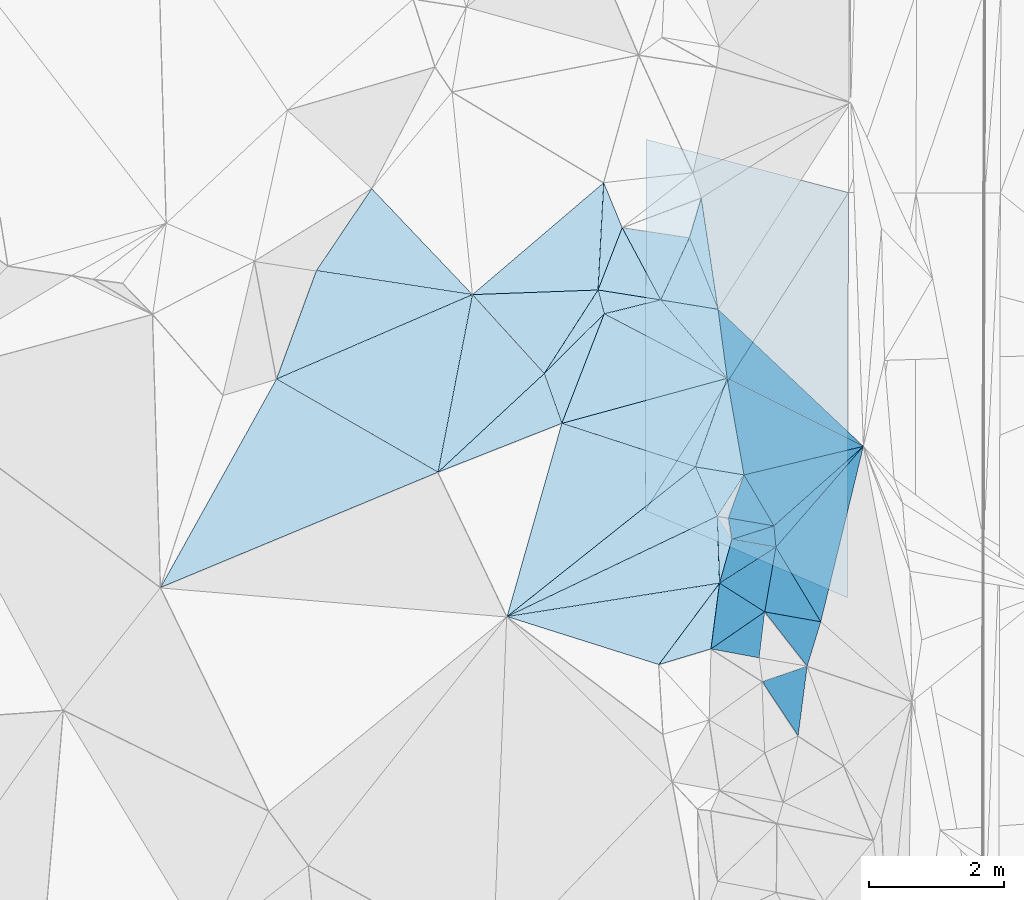
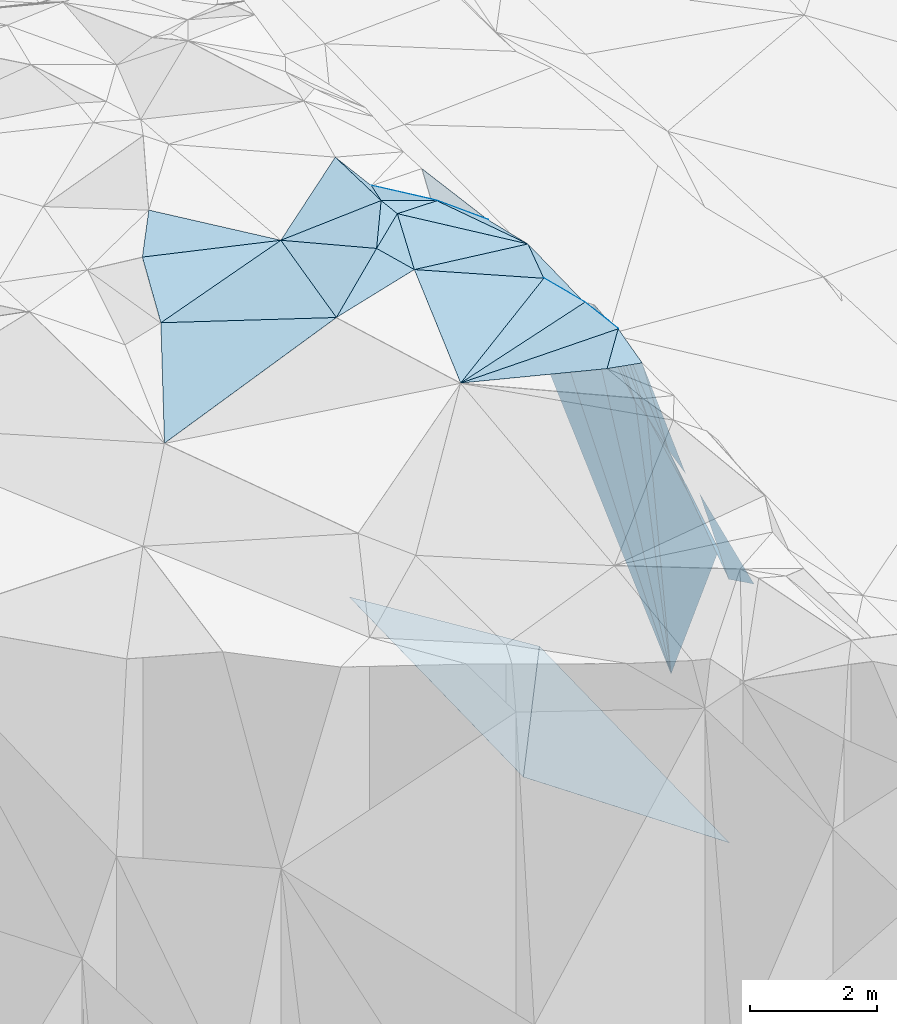
# One storey, part 87 of 275: 45 plates.
"""IFC2X3 building model written with IfcOpenShell, lengths in millimetres."""

import ifcopenshell
import ifcopenshell.guid

model = None  # the IFC model being written
_history = None  # IfcOwnerHistory: only IFC2X3 demands one
_inside = {}  # id of a spatial element -> (the spatial element, [elements in it])
_under = {}  # id of a project, library or spatial element -> (it, [spatial elements below it])
_declared = {}  # id of a project -> (the project, [libraries it declares])
_typed = {}  # id of a type object -> (the type object, [elements of that type])
_made_of = {}  # id of a material, layer set ... -> (it, [elements and type objects made of it])


def new_model(schema):
    """Start an empty IFC model of exactly this schema.

    Asked for "IFC4X3", IfcOpenShell would pick the latest addendum, in which some entities
    have other attributes; the version numbers below select the first issue.
    IFC2X3 requires an IfcOwnerHistory on every rooted entity: one is made here for all.
    """
    global model, _history
    if schema == "IFC4X3":
        model = ifcopenshell.file(schema_version=(4, 3, 0, 0))
    else:
        model = ifcopenshell.file(schema=schema)
    _inside.clear()
    _under.clear()
    _declared.clear()
    _typed.clear()
    _made_of.clear()
    _history = None
    if model.schema == "IFC2X3":
        org = make("IfcOrganization", Name="unknown")
        user = make(
            "IfcPersonAndOrganization",
            ThePerson=make("IfcPerson", FamilyName="unknown"),
            TheOrganization=org,
        )
        app = make(
            "IfcApplication",
            ApplicationDeveloper=org,
            Version="unknown",
            ApplicationFullName="unknown",
            ApplicationIdentifier="unknown",
        )
        _history = make(
            "IfcOwnerHistory",
            OwningUser=user,
            OwningApplication=app,
            ChangeAction="ADDED",
            CreationDate=0,
        )
    return model


def make(cls, **values):
    """One entity of the class cls with the attributes given. An attribute that is None is left unset."""
    return model.create_entity(
        cls, **{name: value for name, value in values.items() if value is not None}
    )


def rooted(cls, **values):
    """An entity with a GlobalId (a new one), such as an element, a storey or a relation."""
    return make(cls, GlobalId=ifcopenshell.guid.new(), OwnerHistory=_history, **values)


def si_unit(unit_type, name, prefix=None):
    """IfcSIUnit, for example si_unit("LENGTHUNIT", "METRE", prefix="MILLI")."""
    return make("IfcSIUnit", UnitType=unit_type, Prefix=prefix, Name=name)


def assignment(units):
    """IfcUnitAssignment: the units of a project."""
    return None if units is None else make("IfcUnitAssignment", Units=units)


def point(xyz):
    """IfcCartesianPoint."""
    return None if xyz is None else make("IfcCartesianPoint", Coordinates=xyz)


def direction(xyz):
    """IfcDirection."""
    return None if xyz is None else make("IfcDirection", DirectionRatios=xyz)


def frame(location, z_axis=None, x_axis=None):
    """IfcAxis2Placement3D, a coordinate frame: its origin and axes. An axis left out is left unset."""
    return make(
        "IfcAxis2Placement3D",
        Location=point(location),
        Axis=direction(z_axis),
        RefDirection=direction(x_axis),
    )


def origin_with_axes():
    """The frame at (0, 0, 0) with the z axis (0, 0, 1) and the x axis (1, 0, 0) written out."""
    return frame((0.0, 0.0, 0.0), z_axis=(0.0, 0.0, 1.0), x_axis=(1.0, 0.0, 0.0))


def place(relative_to, where):
    """IfcLocalPlacement: puts the frame where relative to a parent placement (None: the world)."""
    return make(
        "IfcLocalPlacement", PlacementRelTo=relative_to, RelativePlacement=where
    )


def context(
    kind, dimensions, precision=None, world=None, true_north=None, identifier=None
):
    """IfcGeometricRepresentationContext, for example the 3D "Model" context."""
    return make(
        "IfcGeometricRepresentationContext",
        ContextIdentifier=identifier,
        ContextType=kind,
        CoordinateSpaceDimension=dimensions,
        Precision=precision,
        WorldCoordinateSystem=world,
        TrueNorth=true_north,
    )


def subcontext(parent, identifier, kind, view, scale=None):
    """IfcGeometricRepresentationSubContext, for example "Body" below "Model"."""
    return make(
        "IfcGeometricRepresentationSubContext",
        ContextIdentifier=identifier,
        ContextType=kind,
        ParentContext=parent,
        TargetScale=scale,
        TargetView=view,
    )


def project(units=None, contexts=None):
    """IfcProject with its units and contexts."""
    return rooted(
        "IfcProject",
        Name="project",
        RepresentationContexts=contexts,
        UnitsInContext=assignment(units),
    )


def spatial(cls, under=None, at=None, **own):
    """A site, building, storey or space (cls), placed at a placement, below another one or the project."""
    s = rooted(cls, ObjectPlacement=at, **own)
    if under is not None:
        _under.setdefault(under.id(), (under, []))[1].append(s)
    return s


def polyline(points):
    """IfcPolyline through the points."""
    return make("IfcPolyline", Points=[point(p) for p in points])


def outline(outer, holes=None, kind="AREA"):
    """IfcArbitraryClosedProfileDef: a profile drawn as a closed curve; with holes, ...WithVoids."""
    if holes is None:
        return make("IfcArbitraryClosedProfileDef", ProfileType=kind, OuterCurve=outer)
    return make(
        "IfcArbitraryProfileDefWithVoids",
        ProfileType=kind,
        OuterCurve=outer,
        InnerCurves=holes,
    )


def extrude(swept, where, along, depth):
    """IfcExtrudedAreaSolid: the profile swept, set in the frame where, extruded along a direction by depth."""
    return make(
        "IfcExtrudedAreaSolid",
        SweptArea=swept,
        Position=where,
        ExtrudedDirection=direction(along),
        Depth=depth,
    )


def shape(context_of_items, identifier, shape_type, items):
    """IfcShapeRepresentation: the items that make up one representation, for example the "Body"."""
    return make(
        "IfcShapeRepresentation",
        ContextOfItems=context_of_items,
        RepresentationIdentifier=identifier,
        RepresentationType=shape_type,
        Items=items,
    )


def material(Name=None, Category=None):
    """IfcMaterial."""
    return make("IfcMaterial", Name=Name, Category=Category)


def made_of(thing, what):
    """Note that an element or type object is made of a material, layer set ...; save() writes the relation."""
    if what is not None:
        _made_of.setdefault(what.id(), (what, []))[1].append(thing)
    return thing


def type_object(cls, material=None, **own):
    """A type object (cls), such as IfcWallType, which elements share."""
    return made_of(rooted(cls, **own), material)


def element(
    cls,
    number,
    at=None,
    inside=None,
    cuts=None,
    type_object=None,
    material=None,
    context=None,
    identifier="Body",
    shape_type=None,
    held_by="IfcProductDefinitionShape",
    body=None,
    shapes=None,
    **own,
):
    """One element of the class cls, such as IfcWall. Its Tag is "e" and its number.

    at: its placement. inside: the storey or other place that contains it. cuts: it is an
    opening in that element (IfcRelVoidsElement). A single representation is given by context,
    identifier, shape_type and body (its items); several are given by shapes. held_by: the class
    of the entity that holds the representations. save() writes the other relations.
    """
    e = rooted(cls, Tag="e%d" % number, ObjectPlacement=at, **own)
    if body is not None:
        shapes = [shape(context, identifier, shape_type, body)]
    if shapes is not None:
        e.Representation = make(held_by, Representations=shapes)
    if inside is not None:
        _inside.setdefault(inside.id(), (inside, []))[1].append(e)
    if cuts is not None:
        rooted(
            "IfcRelVoidsElement", RelatingBuildingElement=cuts, RelatedOpeningElement=e
        )
    if type_object is not None:
        _typed.setdefault(type_object.id(), (type_object, []))[1].append(e)
    return made_of(e, material)


def aggregate(whole, parts):
    """IfcRelAggregates: a whole, such as a stair, and the parts it consists of."""
    return rooted("IfcRelAggregates", RelatingObject=whole, RelatedObjects=parts)


def save(model, path):
    """Write the relations noted so far, then the file.

    IfcRelAggregates (storeys below a building ...), IfcRelContainedInSpatialStructure (elements
    in a storey), IfcRelDefinesByType, IfcRelAssociatesMaterial and IfcRelDeclares: one each for
    every whole, place, type object, material and project.
    """
    for whole, parts in _under.values():
        aggregate(whole, parts)
    for where, things in _inside.values():
        rooted(
            "IfcRelContainedInSpatialStructure",
            RelatedElements=things,
            RelatingStructure=where,
        )
    for kind, things in _typed.values():
        rooted("IfcRelDefinesByType", RelatedObjects=things, RelatingType=kind)
    for what, things in _made_of.values():
        rooted("IfcRelAssociatesMaterial", RelatedObjects=things, RelatingMaterial=what)
    for by, libraries in _declared.values():
        rooted("IfcRelDeclares", RelatingContext=by, RelatedDefinitions=libraries)
    model.write(path)


model = new_model("IFC2X3")

# Units and contexts
model_context = context("Model", 3, precision=1e-05, world=origin_with_axes())
body_context = subcontext(model_context, "Body", "Model", "MODEL_VIEW")
ifc_project = project(units=[si_unit("LENGTHUNIT", "METRE", prefix="MILLI"), si_unit("AREAUNIT", "SQUARE_METRE"), si_unit("VOLUMEUNIT", "CUBIC_METRE"), si_unit("MASSUNIT", "GRAM", prefix="KILO"), si_unit("TIMEUNIT", "SECOND"), si_unit("PLANEANGLEUNIT", "RADIAN"), si_unit("SOLIDANGLEUNIT", "STERADIAN"), si_unit("THERMODYNAMICTEMPERATUREUNIT", "DEGREE_CELSIUS"), si_unit("LUMINOUSINTENSITYUNIT", "LUMEN")], contexts=[model_context])

# Site, building, storey
site_placement = place(None, origin_with_axes())
site = spatial("IfcSite", under=ifc_project, at=site_placement, CompositionType="ELEMENT")
building_placement = place(site_placement, origin_with_axes())
building = spatial("IfcBuilding", under=site, at=building_placement, Name="Undefined", CompositionType="ELEMENT")
storey_placement = place(building_placement, origin_with_axes())
storey = spatial("IfcBuildingStorey", under=building, at=storey_placement, Name="Undefined", CompositionType="ELEMENT", Elevation=0.0)

# Plates
ifc_material = material()
plate_type_1 = type_object("IfcPlateType", PredefinedType="NOTDEFINED")
plate_1_placement = place(storey_placement, frame((-107344.660110587, 97239.4910074522, 53279.5045122892), z_axis=(-0.102362017447469, 0.0870254570659908, -0.990933190082227), x_axis=(0.344971449762898, 0.937451020984177, 0.0466934910261504)))
element("IfcPlate", 1, at=plate_1_placement, inside=storey, type_object=plate_type_1, material=ifc_material, Name="00", context=body_context, shape_type="SweptSolid", body=[
    extrude(outline(polyline([(0.0, 0.0), (1713.30090332031, 1.26019585877657e-08), (2164.41845703125, 2310.38818359375), (0.0, 0.0)])), frame((-8.85201319254618e-08, 2.18876761149539e-07, -0.5000001331573), z_axis=(0.0, 0.0, 1.0), x_axis=(1.0, 0.0, 0.0)), (0.0, 0.0, 1.0), 1.0),
])
plate_type_2 = type_object("IfcPlateType", PredefinedType="NOTDEFINED")
plate_2_placement = place(storey_placement, frame((-100815.213242628, 95206.0457130545, 52619.6742989896), z_axis=(-0.754729440093031, -0.0781614138086887, -0.651363389858753), x_axis=(0.475300213105094, -0.749509331662473, -0.460787878717664)))
element("IfcPlate", 2, at=plate_2_placement, inside=storey, type_object=plate_type_2, material=ifc_material, Name="00", context=body_context, shape_type="SweptSolid", body=[
    extrude(outline(polyline([(0.0, 0.0), (455.741149902344, 1.45519152283669e-10), (721.901000976563, 684.513671875), (0.0, 0.0)])), frame((-8.85201319254618e-08, 2.18876761149539e-07, -0.5000001331573), z_axis=(0.0, 0.0, 1.0), x_axis=(1.0, 0.0, 0.0)), (0.0, 0.0, 1.0), 1.0),
])
plate_type_3 = type_object("IfcPlateType", PredefinedType="NOTDEFINED")
plate_3_placement = place(storey_placement, frame((-103378.480245373, 97319.9386348923, 53269.5037275257), z_axis=(0.0415528566033892, -0.11493666031321, -0.992503362323848), x_axis=(-0.668500257960516, 0.735060009693145, -0.113111393133656)))
element("IfcPlate", 3, at=plate_3_placement, inside=storey, type_object=plate_type_3, material=ifc_material, Name="00", context=body_context, shape_type="SweptSolid", body=[
    extrude(outline(polyline([(0.0, 0.0), (1591.35168457031, 2.66118149738759e-09), (389.480224609375, 1424.57189941406), (0.0, 0.0)])), frame((-8.85201319254618e-08, 2.18876761149539e-07, -0.5000001331573), z_axis=(0.0, 0.0, 1.0), x_axis=(1.0, 0.0, 0.0)), (0.0, 0.0, 1.0), 1.0),
])
plate_type_4 = type_object("IfcPlateType", PredefinedType="NOTDEFINED")
plate_4_placement = place(storey_placement, frame((-98871.7360586173, 100000.516631824, 42424.2168338371), z_axis=(-0.446934287543487, 0.0205258010018678, -0.894331277609828), x_axis=(-0.522683826086693, -0.817325183294183, 0.242448268091374)))
element("IfcPlate", 4, at=plate_4_placement, inside=storey, type_object=plate_type_4, material=ifc_material, Name="00_PR", context=body_context, shape_type="SweptSolid", body=[
    extrude(outline(polyline([(0.0, 0.0), (5761.72412109375, -1.54250301420689e-09), (1288.73974609375, 3201.32958984375), (0.0, 0.0)])), frame((-8.85201319254618e-08, 2.18876761149539e-07, -0.5000001331573), z_axis=(0.0, 0.0, 1.0), x_axis=(1.0, 0.0, 0.0)), (0.0, 0.0, 1.0), 1.0),
])
plate_type_5 = type_object("IfcPlateType", PredefinedType="NOTDEFINED")
plate_5_placement = place(storey_placement, frame((-101883.29606058, 95291.3145619174, 43821.1368655032), z_axis=(-0.447056042507758, 0.0206223752256499, -0.894268199421938), x_axis=(0.522683826084668, 0.817325183294846, -0.242448268093504)))
element("IfcPlate", 5, at=plate_5_placement, inside=storey, type_object=plate_type_5, material=ifc_material, Name="00_PR", context=body_context, shape_type="SweptSolid", body=[
    extrude(outline(polyline([(0.0, 0.0), (5761.72412109375, -1.54250301420689e-09), (880.428405761719, 3495.33618164063), (0.0, 0.0)])), frame((-8.85201319254618e-08, 2.18876761149539e-07, -0.5000001331573), z_axis=(0.0, 0.0, 1.0), x_axis=(1.0, 0.0, 0.0)), (0.0, 0.0, 1.0), 1.0),
])
plate_type_6 = type_object("IfcPlateType", PredefinedType="NOTDEFINED")
plate_6_placement = place(storey_placement, frame((-101652.583225246, 98411.0017933798, 52919.6181627559), z_axis=(-0.571172440477387, -0.301041298099992, -0.763633537815998), x_axis=(0.347639344976047, 0.75404379107532, -0.557283452980065)))
element("IfcPlate", 6, at=plate_6_placement, inside=storey, type_object=plate_type_6, material=ifc_material, Name="00", context=body_context, shape_type="SweptSolid", body=[
    extrude(outline(polyline([(0.0, 0.0), (1220.20495605469, -1.57160684466362e-09), (513.602233886719, 901.06201171875), (0.0, 0.0)])), frame((-8.85201319254618e-08, 2.18876761149539e-07, -0.5000001331573), z_axis=(0.0, 0.0, 1.0), x_axis=(1.0, 0.0, 0.0)), (0.0, 0.0, 1.0), 1.0),
])
plate_type_7 = type_object("IfcPlateType", PredefinedType="NOTDEFINED")
plate_7_placement = place(storey_placement, frame((-100781.715139646, 94215.1018659896, 52699.8435163676), z_axis=(-0.941438421919234, 0.125572215780303, -0.312930210044103), x_axis=(0.249200434863564, 0.884299250915346, -0.394859440933566)))
element("IfcPlate", 7, at=plate_7_placement, inside=storey, type_object=plate_type_7, material=ifc_material, Name="00", context=body_context, shape_type="SweptSolid", body=[
    extrude(outline(polyline([(0.0, 0.0), (734.438537597656, 9.45874489843845e-10), (1588.15185546875, 1936.66552734375), (0.0, 0.0)])), frame((-8.85201319254618e-08, 2.18876761149539e-07, -0.5000001331573), z_axis=(0.0, 0.0, 1.0), x_axis=(1.0, 0.0, 0.0)), (0.0, 0.0, 1.0), 1.0),
])
plate_type_8 = type_object("IfcPlateType", PredefinedType="NOTDEFINED")
plate_8_placement = place(storey_placement, frame((-100804.221469901, 98272.3390613483, 52339.8925138729), z_axis=(-0.964955034889042, -0.15055260443843, -0.214931835564427), x_axis=(0.245796147254959, -0.231705745016407, -0.941220857036759)))
element("IfcPlate", 8, at=plate_8_placement, inside=storey, type_object=plate_type_8, material=ifc_material, Name="00", context=body_context, shape_type="SweptSolid", body=[
    extrude(outline(polyline([(0.0, 0.0), (8763.0869140625, 2.7488567866385e-08), (166.634201049805, 1023.97900390625), (0.0, 0.0)])), frame((-8.85201319254618e-08, 2.18876761149539e-07, -0.5000001331573), z_axis=(0.0, 0.0, 1.0), x_axis=(1.0, 0.0, 0.0)), (0.0, 0.0, 1.0), 1.0),
])
plate_type_9 = type_object("IfcPlateType", PredefinedType="NOTDEFINED")
plate_9_placement = place(storey_placement, frame((-100669.018904396, 97249.7342922777, 52449.6394057601), z_axis=(-0.687983318729033, 0.081374169104235, -0.721149913508406), x_axis=(0.165916843196939, -0.949739777549847, -0.265454244801491)))
element("IfcPlate", 9, at=plate_9_placement, inside=storey, type_object=plate_type_9, material=ifc_material, Name="00", context=body_context, shape_type="SweptSolid", body=[
    extrude(outline(polyline([(0.0, 0.0), (1506.85107421875, 4.13274392485619e-09), (1088.4287109375, 920.338439941406), (0.0, 0.0)])), frame((-8.85201319254618e-08, 2.18876761149539e-07, -0.5000001331573), z_axis=(0.0, 0.0, 1.0), x_axis=(1.0, 0.0, 0.0)), (0.0, 0.0, 1.0), 1.0),
])
plate_type_10 = type_object("IfcPlateType", PredefinedType="NOTDEFINED")
plate_10_placement = place(storey_placement, frame((-100419.147354293, 95818.521492825, 52049.8893431669), z_axis=(-0.968814101984016, -0.111519062820364, -0.221275245846824), x_axis=(0.216686648109872, 0.0518643959820866, -0.974862544649409)))
element("IfcPlate", 10, at=plate_10_placement, inside=storey, type_object=plate_type_10, material=ifc_material, Name="00", context=body_context, shape_type="SweptSolid", body=[
    extrude(outline(polyline([(0.0, 0.0), (8163.2021484375, 1.34168658405542e-08), (1577.65783691406, 843.502014160156), (0.0, 0.0)])), frame((-8.85201319254618e-08, 2.18876761149539e-07, -0.5000001331573), z_axis=(0.0, 0.0, 1.0), x_axis=(1.0, 0.0, 0.0)), (0.0, 0.0, 1.0), 1.0),
])
plate_type_11 = type_object("IfcPlateType", PredefinedType="NOTDEFINED")
plate_11_placement = place(storey_placement, frame((-100112.386916383, 93789.4709752747, 50389.8170202238), z_axis=(-0.872840817326139, 0.322876915783165, -0.36592267607213), x_axis=(0.365398242166179, -0.064617253957624, -0.928605801787197)))
element("IfcPlate", 11, at=plate_11_placement, inside=storey, type_object=plate_type_11, material=ifc_material, Name="00", context=body_context, shape_type="SweptSolid", body=[
    extrude(outline(polyline([(0.0, 0.0), (2272.2236328125, -2.17551132664084e-09), (2334.01318359375, 692.157531738281), (0.0, 0.0)])), frame((-8.85201319254618e-08, 2.18876761149539e-07, -0.5000001331573), z_axis=(0.0, 0.0, 1.0), x_axis=(1.0, 0.0, 0.0)), (0.0, 0.0, 1.0), 1.0),
])
plate_type_12 = type_object("IfcPlateType", PredefinedType="NOTDEFINED")
plate_12_placement = place(storey_placement, frame((-100193.973477224, 93108.2299145058, 50379.8495838133), z_axis=(-0.946395220256824, 0.117723884982398, -0.300794238607869), x_axis=(-0.296236861181378, 0.0548833859624551, 0.953536331779079)))
element("IfcPlate", 12, at=plate_12_placement, inside=storey, type_object=plate_type_12, material=ifc_material, Name="00", context=body_context, shape_type="SweptSolid", body=[
    extrude(outline(polyline([(0.0, 0.0), (2412.07373046875, -5.84986992180347e-09), (22.760498046875, 685.698181152344), (0.0, 0.0)])), frame((-8.85201319254618e-08, 2.18876761149539e-07, -0.5000001331573), z_axis=(0.0, 0.0, 1.0), x_axis=(1.0, 0.0, 0.0)), (0.0, 0.0, 1.0), 1.0),
])
plate_13_placement = place(storey_placement, frame((-101652.585016621, 98411.0712264474, 52919.5989324793), z_axis=(-0.57475614055303, -0.162174528284192, -0.802094010245923), x_axis=(0.818156298329736, -0.133767240893072, -0.559219631957999)))
element("IfcPlate", 13, at=plate_13_placement, inside=storey, type_object=plate_type_12, material=ifc_material, Name="00", context=body_context, shape_type="SweptSolid", body=[
    extrude(outline(polyline([(0.0, 0.0), (1037.15954589844, 3.02679836750031e-09), (1222.95544433594, 1020.67620849609), (0.0, 0.0)])), frame((-8.85201319254618e-08, 2.18876761149539e-07, -0.5000001331573), z_axis=(0.0, 0.0, 1.0), x_axis=(1.0, 0.0, 0.0)), (0.0, 0.0, 1.0), 1.0),
])
plate_type_13 = type_object("IfcPlateType", PredefinedType="NOTDEFINED")
plate_14_placement = place(storey_placement, frame((-99975.8941214344, 95063.3567860404, 50489.8403549941), z_axis=(-0.941631828942803, 0.106803743463661, -0.31925297039179), x_axis=(-0.315045255326662, 0.0546446800053478, 0.947502214268268)))
element("IfcPlate", 14, at=plate_14_placement, inside=storey, type_object=plate_type_13, material=ifc_material, Name="00", context=body_context, shape_type="SweptSolid", body=[
    extrude(outline(polyline([(0.0, 0.0), (2142.47509765625, 4.78758011013269e-09), (1659.01574707031, 669.452697753906), (0.0, 0.0)])), frame((-8.85201319254618e-08, 2.18876761149539e-07, -0.5000001331573), z_axis=(0.0, 0.0, 1.0), x_axis=(1.0, 0.0, 0.0)), (0.0, 0.0, 1.0), 1.0),
])
plate_type_14 = type_object("IfcPlateType", PredefinedType="NOTDEFINED")
plate_15_placement = place(storey_placement, frame((-99946.0696637616, 94748.4703674761, 50399.8956807153), z_axis=(-0.977443110590562, -0.033019411700747, -0.208601735395424), x_axis=(-0.0907654072870501, 0.957512935214232, 0.273734578994766)))
element("IfcPlate", 15, at=plate_15_placement, inside=storey, type_object=plate_type_14, material=ifc_material, Name="00", context=body_context, shape_type="SweptSolid", body=[
    extrude(outline(polyline([(0.0, 0.0), (328.78564453125, -2.5029294192791e-09), (-414.3125, 6597.6279296875), (0.0, 0.0)])), frame((-8.85201319254618e-08, 2.18876761149539e-07, -0.5000001331573), z_axis=(0.0, 0.0, 1.0), x_axis=(1.0, 0.0, 0.0)), (0.0, 0.0, 1.0), 1.0),
])
plate_type_15 = type_object("IfcPlateType", PredefinedType="NOTDEFINED")
plate_16_placement = place(storey_placement, frame((-101652.438653701, 98411.0085882198, 52919.542314576), z_axis=(-0.282033278242463, -0.287451493909444, -0.915329923368092), x_axis=(-0.957021666869353, 0.151492729793631, 0.247304431748158)))
element("IfcPlate", 16, at=plate_16_placement, inside=storey, type_object=plate_type_15, material=ifc_material, Name="00", context=body_context, shape_type="SweptSolid", body=[
    extrude(outline(polyline([(0.0, 0.0), (970.463806152344, -8.58562998473644e-10), (669.576721191406, 1024.43493652344), (0.0, 0.0)])), frame((-8.85201319254618e-08, 2.18876761149539e-07, -0.5000001331573), z_axis=(0.0, 0.0, 1.0), x_axis=(1.0, 0.0, 0.0)), (0.0, 0.0, 1.0), 1.0),
])
plate_type_16 = type_object("IfcPlateType", PredefinedType="NOTDEFINED")
plate_17_placement = place(storey_placement, frame((-102490.479406872, 98204.7175444551, 53089.5177065496), z_axis=(-0.228286030459364, 0.132427229372002, -0.964545756933263), x_axis=(-0.244033509207427, 0.951297067808466, 0.188365429850922)))
element("IfcPlate", 17, at=plate_17_placement, inside=storey, type_object=plate_type_16, material=ifc_material, Name="00", context=body_context, shape_type="SweptSolid", body=[
    extrude(outline(polyline([(0.0, 0.0), (371.618072509766, -3.34694050252438e-10), (-40.0949287414551, 878.801696777344), (0.0, 0.0)])), frame((-8.85201319254618e-08, 2.18876761149539e-07, -0.5000001331573), z_axis=(0.0, 0.0, 1.0), x_axis=(1.0, 0.0, 0.0)), (0.0, 0.0, 1.0), 1.0),
])
plate_type_17 = type_object("IfcPlateType", PredefinedType="NOTDEFINED")
plate_18_placement = place(storey_placement, frame((-100668.794257987, 97249.7854669593, 52449.5232018861), z_axis=(-0.23869593819257, 0.183721524600985, -0.953556841771196), x_axis=(-0.845689402985507, 0.443323216734611, 0.29710933876621)))
element("IfcPlate", 18, at=plate_18_placement, inside=storey, type_object=plate_type_17, material=ifc_material, Name="00", context=body_context, shape_type="SweptSolid", body=[
    extrude(outline(polyline([(0.0, 0.0), (2154.08911132813, 2.17551132664084e-09), (1486.38232421875, 572.771850585938), (0.0, 0.0)])), frame((-8.85201319254618e-08, 2.18876761149539e-07, -0.5000001331573), z_axis=(0.0, 0.0, 1.0), x_axis=(1.0, 0.0, 0.0)), (0.0, 0.0, 1.0), 1.0),
])
plate_type_18 = type_object("IfcPlateType", PredefinedType="NOTDEFINED")
plate_19_placement = place(storey_placement, frame((-101680.208855018, 93008.4579098496, 52979.50861603), z_axis=(-0.0866350012075543, -0.163519365232123, -0.982728748821286), x_axis=(-0.952951068923403, 0.30122391275125, 0.0338882667684678)))
element("IfcPlate", 19, at=plate_19_placement, inside=storey, type_object=plate_type_18, material=ifc_material, Name="00", context=body_context, shape_type="SweptSolid", body=[
    extrude(outline(polyline([(0.0, 0.0), (2360.69897460938, 1.97906047105789e-09), (-502.690093994141, 1445.47668457031), (0.0, 0.0)])), frame((-8.85201319254618e-08, 2.18876761149539e-07, -0.5000001331573), z_axis=(0.0, 0.0, 1.0), x_axis=(1.0, 0.0, 0.0)), (0.0, 0.0, 1.0), 1.0),
])
plate_type_19 = type_object("IfcPlateType", PredefinedType="NOTDEFINED")
plate_20_placement = place(storey_placement, frame((-100781.433956859, 94215.0732117764, 52699.5385587893), z_axis=(-0.379075628872105, 0.06826585103134, -0.9228442128432), x_axis=(-0.129006544744459, -0.991434957826339, -0.0203478699863755)))
element("IfcPlate", 20, at=plate_20_placement, inside=storey, type_object=plate_type_19, material=ifc_material, Name="00", context=body_context, shape_type="SweptSolid", body=[
    extrude(outline(polyline([(0.0, 0.0), (982.903869628906, 6.81029632687569e-09), (1306.43493652344, 797.074401855469), (0.0, 0.0)])), frame((-8.85201319254618e-08, 2.18876761149539e-07, -0.5000001331573), z_axis=(0.0, 0.0, 1.0), x_axis=(1.0, 0.0, 0.0)), (0.0, 0.0, 1.0), 1.0),
])
plate_type_20 = type_object("IfcPlateType", PredefinedType="NOTDEFINED")
plate_21_placement = place(storey_placement, frame((-100814.88599314, 95206.0430804497, 52619.5042503508), z_axis=(-0.100234591356631, -0.0834308647266623, -0.991459690308452), x_axis=(0.0337658032048205, -0.996189371820995, 0.0804152100340744)))
element("IfcPlate", 21, at=plate_21_placement, inside=storey, type_object=plate_type_20, material=ifc_material, Name="00", context=body_context, shape_type="SweptSolid", body=[
    extrude(outline(polyline([(0.0, 0.0), (994.836669921875, 8.29459168016911e-10), (1410.9853515625, 3180.443359375), (0.0, 0.0)])), frame((-8.85201319254618e-08, 2.18876761149539e-07, -0.5000001331573), z_axis=(0.0, 0.0, 1.0), x_axis=(1.0, 0.0, 0.0)), (0.0, 0.0, 1.0), 1.0),
])
plate_type_21 = type_object("IfcPlateType", PredefinedType="NOTDEFINED")
plate_22_placement = place(storey_placement, frame((-103378.55080737, 97320.0122386982, 53269.5027170647), z_axis=(-0.0994864296260352, 0.0322758273111082, -0.994515319787306), x_axis=(0.332327347639212, -0.941004880829664, -0.06378360499248)))
element("IfcPlate", 22, at=plate_22_placement, inside=storey, type_object=plate_type_21, material=ifc_material, Name="00", context=body_context, shape_type="SweptSolid", body=[
    extrude(outline(polyline([(0.0, 0.0), (783.900512695313, -5.70435076951981e-09), (844.877624511719, 1977.1650390625), (0.0, 0.0)])), frame((-8.85201319254618e-08, 2.18876761149539e-07, -0.5000001331573), z_axis=(0.0, 0.0, 1.0), x_axis=(1.0, 0.0, 0.0)), (0.0, 0.0, 1.0), 1.0),
])
plate_type_22 = type_object("IfcPlateType", PredefinedType="NOTDEFINED")
plate_23_placement = place(storey_placement, frame((-100112.41978631, 93789.3925115726, 50389.8487177517), z_axis=(-0.938582630391391, 0.165951424860966, -0.302527305402658), x_axis=(-0.274031657311512, 0.174308130014904, 0.945792433148951)))
element("IfcPlate", 23, at=plate_23_placement, inside=storey, type_object=plate_type_22, material=ifc_material, Name="00", context=body_context, shape_type="SweptSolid", body=[
    extrude(outline(polyline([(0.0, 0.0), (2442.396484375, 4.14729584008455e-09), (131.059814453125, 964.688171386719), (0.0, 0.0)])), frame((-8.85201319254618e-08, 2.18876761149539e-07, -0.5000001331573), z_axis=(0.0, 0.0, 1.0), x_axis=(1.0, 0.0, 0.0)), (0.0, 0.0, 1.0), 1.0),
])
plate_type_23 = type_object("IfcPlateType", PredefinedType="NOTDEFINED")
plate_24_placement = place(storey_placement, frame((-105934.903532407, 100060.353808086, 53239.5035985636), z_axis=(-0.118750753045522, -0.0180337586479, -0.992760314577568), x_axis=(0.687208357335265, -0.723169892053667, -0.0690650478581938)))
element("IfcPlate", 24, at=plate_24_placement, inside=storey, type_object=plate_type_23, material=ifc_material, Name="00", context=body_context, shape_type="SweptSolid", body=[
    extrude(outline(polyline([(0.0, 0.0), (2171.86547851563, 1.43554643727839e-08), (307.569671630859, 1437.28942871094), (0.0, 0.0)])), frame((-8.85201319254618e-08, 2.18876761149539e-07, -0.5000001331573), z_axis=(0.0, 0.0, 1.0), x_axis=(1.0, 0.0, 0.0)), (0.0, 0.0, 1.0), 1.0),
])
plate_type_24 = type_object("IfcPlateType", PredefinedType="NOTDEFINED")
plate_25_placement = place(storey_placement, frame((-102224.104605899, 99481.2500253093, 52759.6006950824), z_axis=(-0.473142042835989, -0.372055464178987, -0.798568305704369), x_axis=(0.878594200230698, -0.13252284886064, -0.458813606871942)))
element("IfcPlate", 25, at=plate_25_placement, inside=storey, type_object=plate_type_24, material=ifc_material, Name="00", context=body_context, shape_type="SweptSolid", body=[
    extrude(outline(polyline([(0.0, 0.0), (1133.35778808594, 1.76078174263239e-09), (570.605285644531, 1082.68627929688), (0.0, 0.0)])), frame((-8.85201319254618e-08, 2.18876761149539e-07, -0.5000001331573), z_axis=(0.0, 0.0, 1.0), x_axis=(1.0, 0.0, 0.0)), (0.0, 0.0, 1.0), 1.0),
])
plate_type_25 = type_object("IfcPlateType", PredefinedType="NOTDEFINED")
plate_26_placement = place(storey_placement, frame((-102581.203351381, 98558.2255956234, 53159.5264615429), z_axis=(-0.301647010332855, 0.110141143374922, -0.947036435251208), x_axis=(0.24403350922126, -0.95129706780404, -0.188365429855355)))
element("IfcPlate", 26, at=plate_26_placement, inside=storey, type_object=plate_type_25, material=ifc_material, Name="00", context=body_context, shape_type="SweptSolid", body=[
    extrude(outline(polyline([(0.0, 0.0), (371.618072509766, -3.34694050252438e-10), (962.54736328125, 1120.09045410156), (0.0, 0.0)])), frame((-8.85201319254618e-08, 2.18876761149539e-07, -0.5000001331573), z_axis=(0.0, 0.0, 1.0), x_axis=(1.0, 0.0, 0.0)), (0.0, 0.0, 1.0), 1.0),
])
plate_type_26 = type_object("IfcPlateType", PredefinedType="NOTDEFINED")
plate_27_placement = place(storey_placement, frame((-102490.520518681, 98204.6733511666, 53089.5252050554), z_axis=(-0.310511981768277, 0.0440381357937831, -0.949548814845317), x_axis=(0.845689402974647, -0.443323216760005, -0.29710933875923)))
element("IfcPlate", 27, at=plate_27_placement, inside=storey, type_object=plate_type_26, material=ifc_material, Name="00", context=body_context, shape_type="SweptSolid", body=[
    extrude(outline(polyline([(0.0, 0.0), (2154.08911132813, 2.17551132664084e-09), (149.80810546875, 1737.88879394531), (0.0, 0.0)])), frame((-8.85201319254618e-08, 2.18876761149539e-07, -0.5000001331573), z_axis=(0.0, 0.0, 1.0), x_axis=(1.0, 0.0, 0.0)), (0.0, 0.0, 1.0), 1.0),
])
plate_type_27 = type_object("IfcPlateType", PredefinedType="NOTDEFINED")
plate_28_placement = place(storey_placement, frame((-101138.444240057, 95937.709022598, 52749.5220693037), z_axis=(-0.266972180134134, -0.123000398713059, -0.955822555159092), x_axis=(-0.927527263258088, 0.301997252844787, 0.220206346836697)))
element("IfcPlate", 28, at=plate_28_placement, inside=storey, type_object=plate_type_27, material=ifc_material, Name="00", context=body_context, shape_type="SweptSolid", body=[
    extrude(outline(polyline([(0.0, 0.0), (2134.36181640625, -1.04118953458965e-08), (-105.464782714844, 1421.47009277344), (0.0, 0.0)])), frame((-8.85201319254618e-08, 2.18876761149539e-07, -0.5000001331573), z_axis=(0.0, 0.0, 1.0), x_axis=(1.0, 0.0, 0.0)), (0.0, 0.0, 1.0), 1.0),
])
plate_type_28 = type_object("IfcPlateType", PredefinedType="NOTDEFINED")
plate_29_placement = place(storey_placement, frame((-99975.8988792316, 95063.3024326882, 50489.8456187418), z_axis=(-0.951149275832967, -0.00190348107853032, -0.308725495938068), x_axis=(0.0907654072841026, -0.957512935215651, -0.273734578990782)))
element("IfcPlate", 29, at=plate_29_placement, inside=storey, type_object=plate_type_28, material=ifc_material, Name="00", context=body_context, shape_type="SweptSolid", body=[
    extrude(outline(polyline([(0.0, 0.0), (328.78564453125, -2.5029294192791e-09), (-391.744598388672, 1990.05932617188), (0.0, 0.0)])), frame((-8.85201319254618e-08, 2.18876761149539e-07, -0.5000001331573), z_axis=(0.0, 0.0, 1.0), x_axis=(1.0, 0.0, 0.0)), (0.0, 0.0, 1.0), 1.0),
])
plate_30_placement = place(storey_placement, frame((-100598.696338798, 94864.4786382776, 52409.8436457132), z_axis=(-0.948656901720369, -0.0478198247746867, -0.312671308528346), x_axis=(-0.154132647215073, 0.93309082360794, 0.324937904777406)))
element("IfcPlate", 30, at=plate_30_placement, inside=storey, type_object=plate_type_28, material=ifc_material, Name="00", context=body_context, shape_type="SweptSolid", body=[
    extrude(outline(polyline([(0.0, 0.0), (338.526214599609, 1.42608769237995e-09), (-534.375183105469, 1956.58972167969), (0.0, 0.0)])), frame((-8.85201319254618e-08, 2.18876761149539e-07, -0.5000001331573), z_axis=(0.0, 0.0, 1.0), x_axis=(1.0, 0.0, 0.0)), (0.0, 0.0, 1.0), 1.0),
])
plate_type_29 = type_object("IfcPlateType", PredefinedType="NOTDEFINED")
plate_31_placement = place(storey_placement, frame((-104442.300364722, 98489.6765438128, 53089.503801441), z_axis=(0.0392605651328663, -0.116998668753193, -0.992355742430822), x_axis=(0.668500257964939, -0.735060009689736, 0.113111393129671)))
element("IfcPlate", 31, at=plate_31_placement, inside=storey, type_object=plate_type_29, material=ifc_material, Name="00", context=body_context, shape_type="SweptSolid", body=[
    extrude(outline(polyline([(0.0, 0.0), (1591.35168457031, 2.66118149738759e-09), (1625.78771972656, 2149.84057617188), (0.0, 0.0)])), frame((-8.85201319254618e-08, 2.18876761149539e-07, -0.5000001331573), z_axis=(0.0, 0.0, 1.0), x_axis=(1.0, 0.0, 0.0)), (0.0, 0.0, 1.0), 1.0),
])
plate_type_30 = type_object("IfcPlateType", PredefinedType="NOTDEFINED")
plate_32_placement = place(storey_placement, frame((-99282.1657163435, 93642.4162570834, 48279.884825964), z_axis=(-0.963444804926493, -0.136860360741239, -0.230311418557419), x_axis=(-0.267526449315443, 0.445678865051812, 0.854283295027358)))
element("IfcPlate", 32, at=plate_32_placement, inside=storey, type_object=plate_type_30, material=ifc_material, Name="00", context=body_context, shape_type="SweptSolid", body=[
    extrude(outline(polyline([(0.0, 0.0), (2481.6123046875, 1.33804860524833e-08), (-2588.25268554688, 4242.265625), (0.0, 0.0)])), frame((-8.85201319254618e-08, 2.18876761149539e-07, -0.5000001331573), z_axis=(0.0, 0.0, 1.0), x_axis=(1.0, 0.0, 0.0)), (0.0, 0.0, 1.0), 1.0),
])
plate_type_31 = type_object("IfcPlateType", PredefinedType="NOTDEFINED")
plate_33_placement = place(storey_placement, frame((-99946.03808306, 94748.5681026502, 50399.8144475976), z_axis=(-0.914285658311525, 0.162451682650694, -0.371067629698173), x_axis=(0.26752644932045, -0.445678865034267, -0.854283295034943)))
element("IfcPlate", 33, at=plate_33_placement, inside=storey, type_object=plate_type_31, material=ifc_material, Name="00", context=body_context, shape_type="SweptSolid", body=[
    extrude(outline(polyline([(0.0, 0.0), (2481.6123046875, 1.33804860524833e-08), (391.519653320313, 891.354248046875), (0.0, 0.0)])), frame((-8.85201319254618e-08, 2.18876761149539e-07, -0.5000001331573), z_axis=(0.0, 0.0, 1.0), x_axis=(1.0, 0.0, 0.0)), (0.0, 0.0, 1.0), 1.0),
])
plate_type_32 = type_object("IfcPlateType", PredefinedType="NOTDEFINED")
plate_34_placement = place(storey_placement, frame((-102496.682711894, 100147.988976521, 52999.5030231561), z_axis=(0.0411377959971389, -0.102207057201151, -0.993912168754754), x_axis=(-0.0527141628238743, -0.99359085108929, 0.0999921880420579)))
element("IfcPlate", 34, at=plate_34_placement, inside=storey, type_object=plate_type_32, material=ifc_material, Name="00", context=body_context, shape_type="SweptSolid", body=[
    extrude(outline(polyline([(0.0, 0.0), (1600.125, -1.07393134385347e-08), (1759.23754882813, 1857.0361328125), (0.0, 0.0)])), frame((-8.85201319254618e-08, 2.18876761149539e-07, -0.5000001331573), z_axis=(0.0, 0.0, 1.0), x_axis=(1.0, 0.0, 0.0)), (0.0, 0.0, 1.0), 1.0),
])
plate_type_33 = type_object("IfcPlateType", PredefinedType="NOTDEFINED")
plate_35_placement = place(storey_placement, frame((-100803.500464123, 98272.4687555052, 52339.5639282224), z_axis=(0.477064793837161, 0.108837969335189, -0.872102906148179), x_axis=(-0.370601827279075, 0.924677070134172, -0.0873304161532182)))
element("IfcPlate", 35, at=plate_35_placement, inside=storey, type_object=plate_type_33, material=ifc_material, Name="00", context=body_context, shape_type="SweptSolid", body=[
    extrude(outline(polyline([(0.0, 0.0), (1145.07641601563, -5.62431523576379e-09), (1612.11950683594, 437.802215576172), (0.0, 0.0)])), frame((-8.85201319254618e-08, 2.18876761149539e-07, -0.5000001331573), z_axis=(0.0, 0.0, 1.0), x_axis=(1.0, 0.0, 0.0)), (0.0, 0.0, 1.0), 1.0),
])
plate_type_34 = type_object("IfcPlateType", PredefinedType="NOTDEFINED")
plate_36_placement = place(storey_placement, frame((-101138.402100295, 95937.8170882462, 52749.5106054236), z_axis=(-0.182692697761315, 0.0931286804205928, -0.978749419957842), x_axis=(0.399108452283494, -0.902765498008865, -0.160396068906566)))
element("IfcPlate", 36, at=plate_36_placement, inside=storey, type_object=plate_type_34, material=ifc_material, Name="00", context=body_context, shape_type="SweptSolid", body=[
    extrude(outline(polyline([(0.0, 0.0), (810.49365234375, -9.45874489843845e-10), (838.624694824219, 3479.26831054688), (0.0, 0.0)])), frame((-8.85201319254618e-08, 2.18876761149539e-07, -0.5000001331573), z_axis=(0.0, 0.0, 1.0), x_axis=(1.0, 0.0, 0.0)), (0.0, 0.0, 1.0), 1.0),
])
plate_type_35 = type_object("IfcPlateType", PredefinedType="NOTDEFINED")
plate_37_placement = place(storey_placement, frame((-100781.717334935, 94215.1036722693, 52699.8510554594), z_axis=(-0.945830664122825, 0.129185467093483, -0.297851422519373), x_axis=(0.274031657312852, -0.174308130016524, -0.945792433148265)))
element("IfcPlate", 37, at=plate_37_placement, inside=storey, type_object=plate_type_35, material=ifc_material, Name="00", context=body_context, shape_type="SweptSolid", body=[
    extrude(outline(polyline([(0.0, 0.0), (2442.396484375, 4.14729584008455e-09), (154.029052734375, 970.760009765625), (0.0, 0.0)])), frame((-8.85201319254618e-08, 2.18876761149539e-07, -0.5000001331573), z_axis=(0.0, 0.0, 1.0), x_axis=(1.0, 0.0, 0.0)), (0.0, 0.0, 1.0), 1.0),
])
plate_type_36 = type_object("IfcPlateType", PredefinedType="NOTDEFINED")
plate_38_placement = place(storey_placement, frame((-99617.4941729221, 91952.5610952146, 48759.8418964707), z_axis=(-0.947125592706739, -0.0546746655238685, -0.316170511891546), x_axis=(-0.304713185282632, 0.461944652974474, 0.83292077192444)))
element("IfcPlate", 38, at=plate_38_placement, inside=storey, type_object=plate_type_36, material=ifc_material, Name="00", context=body_context, shape_type="SweptSolid", body=[
    extrude(outline(polyline([(0.0, 0.0), (1740.86181640625, -3.14685166813433e-09), (-47.0456619262695, 1190.75048828125), (0.0, 0.0)])), frame((-8.85201319254618e-08, 2.18876761149539e-07, -0.5000001331573), z_axis=(0.0, 0.0, 1.0), x_axis=(1.0, 0.0, 0.0)), (0.0, 0.0, 1.0), 1.0),
])
plate_type_37 = type_object("IfcPlateType", PredefinedType="NOTDEFINED")
plate_39_placement = place(storey_placement, frame((-103929.894003134, 93719.6936393834, 53059.5127258508), z_axis=(-0.195569234192579, 0.10992615535859, -0.974509576661722), x_axis=(0.272429116878146, 0.960676530386757, 0.0536933910370279)))
element("IfcPlate", 39, at=plate_39_placement, inside=storey, type_object=plate_type_37, material=ifc_material, Name="00", context=body_context, shape_type="SweptSolid", body=[
    extrude(outline(polyline([(0.0, 0.0), (2979.88256835938, -1.41153577715158e-08), (2874.744140625, 2131.7705078125), (0.0, 0.0)])), frame((-8.85201319254618e-08, 2.18876761149539e-07, -0.5000001331573), z_axis=(0.0, 0.0, 1.0), x_axis=(1.0, 0.0, 0.0)), (0.0, 0.0, 1.0), 1.0),
])
plate_type_38 = type_object("IfcPlateType", PredefinedType="NOTDEFINED")
plate_40_placement = place(storey_placement, frame((-100815.186213528, 95205.9910709364, 52619.6557712304), z_axis=(-0.700671457484305, -0.187450764903666, -0.688419726187339), x_axis=(-0.39910845227774, 0.902765498016104, 0.160396068880141)))
element("IfcPlate", 40, at=plate_40_placement, inside=storey, type_object=plate_type_38, material=ifc_material, Name="00", context=body_context, shape_type="SweptSolid", body=[
    extrude(outline(polyline([(0.0, 0.0), (810.49365234375, -9.45874489843845e-10), (303.395324707031, 874.614929199219), (0.0, 0.0)])), frame((-8.85201319254618e-08, 2.18876761149539e-07, -0.5000001331573), z_axis=(0.0, 0.0, 1.0), x_axis=(1.0, 0.0, 0.0)), (0.0, 0.0, 1.0), 1.0),
])
plate_type_39 = type_object("IfcPlateType", PredefinedType="NOTDEFINED")
plate_41_placement = place(storey_placement, frame((-107344.60443183, 97239.41913312, 53279.5008047944), z_axis=(0.00899667044436349, -0.0567263834518543, -0.998349226143532), x_axis=(0.865585963884376, -0.499451703680851, 0.0361792042014599)))
element("IfcPlate", 41, at=plate_41_placement, inside=storey, type_object=plate_type_39, material=ifc_material, Name="00", context=body_context, shape_type="SweptSolid", body=[
    extrude(outline(polyline([(0.0, 0.0), (2764.01879882813, -2.29629222303629e-08), (61.251392364502, 3537.11010742188), (0.0, 0.0)])), frame((-8.85201319254618e-08, 2.18876761149539e-07, -0.5000001331573), z_axis=(0.0, 0.0, 1.0), x_axis=(1.0, 0.0, 0.0)), (0.0, 0.0, 1.0), 1.0),
])
plate_type_40 = type_object("IfcPlateType", PredefinedType="NOTDEFINED")
plate_42_placement = place(storey_placement, frame((-104952.12279126, 95858.9006836912, 53379.5028827476), z_axis=(-0.0195013091249478, -0.105814496404179, -0.994194644570742), x_axis=(-0.865585963884052, 0.499451703682467, -0.0361792041869032)))
element("IfcPlate", 42, at=plate_42_placement, inside=storey, type_object=plate_type_40, material=ifc_material, Name="00", context=body_context, shape_type="SweptSolid", body=[
    extrude(outline(polyline([(0.0, 0.0), (2764.01879882813, -2.29629222303629e-08), (883.170532226563, 2546.568359375), (0.0, 0.0)])), frame((-8.85201319254618e-08, 2.18876761149539e-07, -0.5000001331573), z_axis=(0.0, 0.0, 1.0), x_axis=(1.0, 0.0, 0.0)), (0.0, 0.0, 1.0), 1.0),
])
plate_type_41 = type_object("IfcPlateType", PredefinedType="NOTDEFINED")
plate_43_placement = place(storey_placement, frame((-103118.087449763, 96582.3405252411, 53219.509680055), z_axis=(-0.195998826799486, -0.00275189866602199, -0.98060026868595), x_axis=(-0.332327347249313, 0.941004880973984, 0.0637836048947785)))
element("IfcPlate", 43, at=plate_43_placement, inside=storey, type_object=plate_type_41, material=ifc_material, Name="00", context=body_context, shape_type="SweptSolid", body=[
    extrude(outline(polyline([(0.0, 0.0), (783.900512695313, -5.70435076951981e-09), (1309.73254394531, 1152.08532714844), (0.0, 0.0)])), frame((-8.85201319254618e-08, 2.18876761149539e-07, -0.5000001331573), z_axis=(0.0, 0.0, 1.0), x_axis=(1.0, 0.0, 0.0)), (0.0, 0.0, 1.0), 1.0),
])
plate_type_42 = type_object("IfcPlateType", PredefinedType="NOTDEFINED")
plate_44_placement = place(storey_placement, frame((-100669.159555941, 97249.6398484692, 52449.8893962037), z_axis=(-0.969291001238666, -0.107515401176985, -0.221168246878924), x_axis=(0.233200487225186, -0.116404149995334, -0.965436485027265)))
element("IfcPlate", 44, at=plate_44_placement, inside=storey, type_object=plate_type_42, material=ifc_material, Name="00", context=body_context, shape_type="SweptSolid", body=[
    extrude(outline(polyline([(0.0, 0.0), (8657.2236328125, -8.49831849336624e-09), (611.065368652344, 1377.38854980469), (0.0, 0.0)])), frame((-8.85201319254618e-08, 2.18876761149539e-07, -0.5000001331573), z_axis=(0.0, 0.0, 1.0), x_axis=(1.0, 0.0, 0.0)), (0.0, 0.0, 1.0), 1.0),
])
plate_type_43 = type_object("IfcPlateType", PredefinedType="NOTDEFINED")
plate_45_placement = place(storey_placement, frame((-102497.055991343, 100148.023167214, 52999.6459877256), z_axis=(-0.705418942855022, -0.03382399229491, -0.707983087796973), x_axis=(0.359367242239514, -0.878023109872304, -0.316118021845219)))
element("IfcPlate", 45, at=plate_45_placement, inside=storey, type_object=plate_type_43, material=ifc_material, Name="00", context=body_context, shape_type="SweptSolid", body=[
    extrude(outline(polyline([(0.0, 0.0), (759.210144042969, -6.40284270048141e-10), (1315.05102539063, 911.614440917969), (0.0, 0.0)])), frame((-8.85201319254618e-08, 2.18876761149539e-07, -0.5000001331573), z_axis=(0.0, 0.0, 1.0), x_axis=(1.0, 0.0, 0.0)), (0.0, 0.0, 1.0), 1.0),
])

save(model, "model.ifc")
